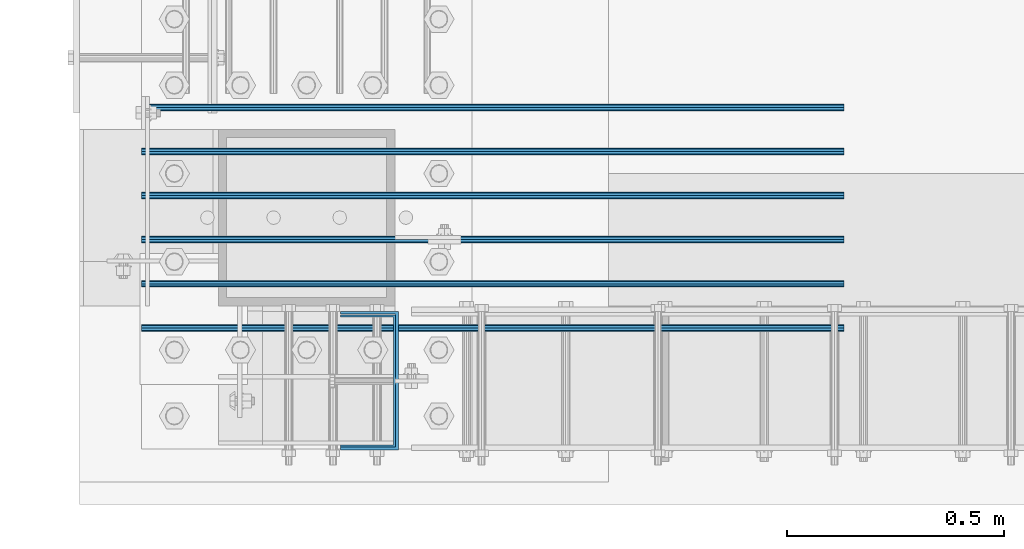
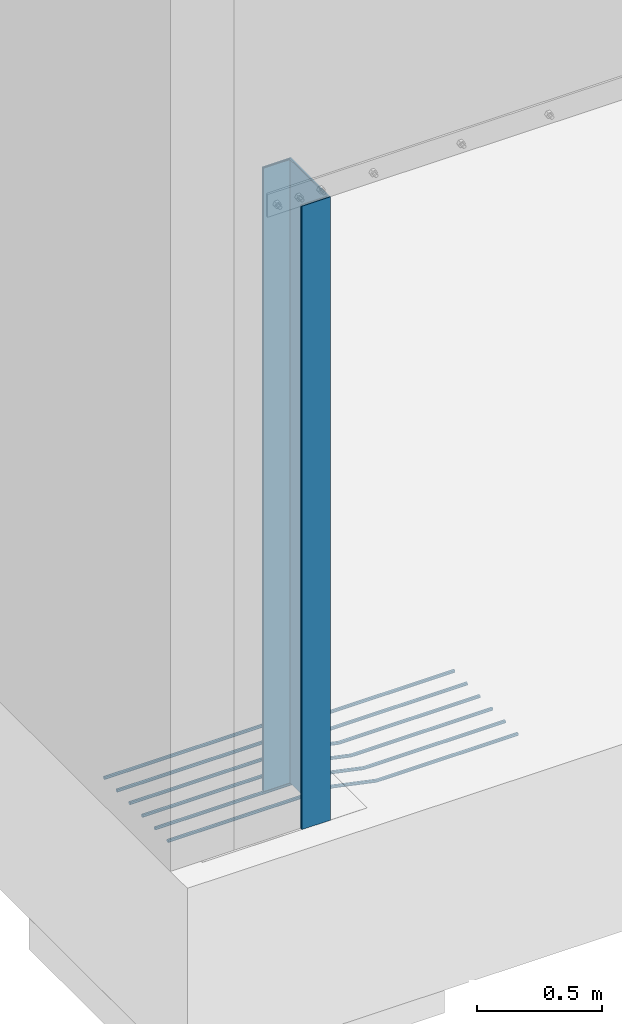
# One storey, part 906 of 1876: 8 beams, 3 elements without a shape of their own.
"""IFC2X3 building model written with IfcOpenShell, lengths in millimetres."""

from ifc_helpers import new_model, si_unit, frame, origin_with_axes, place, context, subcontext, project, spatial, faceted_brep, material, type_object, element, aggregate, save


model = new_model("IFC2X3")

# Units and contexts
model_context = context("Model", 3, precision=1e-05, world=origin_with_axes())
body_context = subcontext(model_context, "Body", "Model", "MODEL_VIEW")
ifc_project = project(units=[si_unit("LENGTHUNIT", "METRE", prefix="MILLI"), si_unit("AREAUNIT", "SQUARE_METRE"), si_unit("VOLUMEUNIT", "CUBIC_METRE"), si_unit("MASSUNIT", "GRAM", prefix="KILO"), si_unit("TIMEUNIT", "SECOND"), si_unit("PLANEANGLEUNIT", "RADIAN"), si_unit("SOLIDANGLEUNIT", "STERADIAN"), si_unit("THERMODYNAMICTEMPERATUREUNIT", "DEGREE_CELSIUS"), si_unit("LUMINOUSINTENSITYUNIT", "LUMEN")], contexts=[model_context])

# Site, building, storey
site_placement = place(None, origin_with_axes())
site = spatial("IfcSite", under=ifc_project, at=site_placement, CompositionType="ELEMENT")
building_placement = place(site_placement, origin_with_axes())
building = spatial("IfcBuilding", under=site, at=building_placement, Name="Undefined", CompositionType="ELEMENT")
storey_placement = place(building_placement, origin_with_axes())
storey = spatial("IfcBuildingStorey", under=building, at=storey_placement, Name="Undefined", CompositionType="ELEMENT", Elevation=0.0)

# Assembly, beams
assembly_1_placement = place(storey_placement, origin_with_axes())
assembly_1 = element("IfcElementAssembly", 1, at=assembly_1_placement, inside=storey, Name="PLATE", AssemblyPlace="NOTDEFINED", PredefinedType="RIGID_FRAME")
ifc_material_1 = material(Name="STEEL/A706-GR.60")
beam_type_1 = type_object("IfcBeamType", Name="5 REBAR", PredefinedType="NOTDEFINED")
beam_1_placement = place(assembly_1_placement, frame((-149.225003184072, -25349.2, -65.0875000000029), z_axis=(0.0, -1.0, 0.0), x_axis=(1.0, 0.0, 0.0)))
beam_1 = element("IfcBeam", 2, at=beam_1_placement, type_object=beam_type_1, material=ifc_material_1, Name="REBAR", ObjectType="5 REBAR", context=body_context, shape_type="Brep", body=[
    faceted_brep([(0.0, -7.9375, 0.0), (0.0, -5.61266007566822, -5.61266007566883), (760.671952535711, -5.61266007566822, -5.61266007566883), (760.671952535711, -7.9375, 0.0), (0.0, 0.0, -7.9375), (760.671952535711, 0.0, -7.9375), (0.0, 5.61266007566822, -5.61266007566883), (760.671952535711, 5.61266007566822, -5.61266007566883), (0.0, 7.9375, 0.0), (760.671952535711, 7.9375, 0.0), (0.0, 5.61266007566822, 5.61266007566883), (760.671952535711, 5.61266007566822, 5.61266007566883), (0.0, 0.0, 7.9375), (760.671952535711, 0.0, 7.9375), (0.0, -5.61266007566822, 5.61266007566883), (760.671952535711, -5.61266007566822, 5.61266007566883), (761.414482022857, -5.61266007566822, -5.61266007566883), (761.17195253571, -7.9375, 0.0), (762.0, 0.0, -7.9375), (762.585517977143, 5.61266007566822, -5.61266007566883), (762.82804746429, 7.9375, 0.0), (762.585517977143, 5.61266007566822, 5.61266007566883), (762.0, 0.0, 7.9375), (761.414482022857, -5.61266007566822, 5.61266007566883), (762.141023814993, -5.76591497301254, -5.61266007566883), (761.661186838667, -8.04069785274343, 0.0), (763.299452750969, -0.274103293312095, -7.9375), (764.457881686945, 5.21770838638835, -5.61266007566883), (764.937718663271, 7.49249126611924, 0.0), (764.457881686945, 5.21770838638835, 5.61266007566883), (763.299452750969, -0.274103293312095, 7.9375), (762.141023814993, -5.76591497301254, 5.61266007566883), (962.742130520086, -48.0802076234489, -5.61266007566883), (962.26229354376, -50.3549905031798, 0.0), (963.900559456062, -42.5883959437485, -7.9375), (965.058988392038, -37.096584264048, -5.61266007566883), (965.538825368364, -34.8218013843171, 0.0), (965.058988392038, -37.096584264048, 5.61266007566883), (963.900559456062, -42.5883959437485, 7.9375), (962.742130520086, -48.0802076234489, 5.61266007566883), (964.614494229888, -48.4751593127288, -5.61266007566883), (964.371964742742, -50.7999992370605, 0.0), (965.200012207031, -42.8624992370605, -7.9375), (965.785530184175, -37.2498391613923, -5.61266007566883), (966.028059671321, -34.9249992370605, 0.0), (965.785530184175, -37.2498391613923, 5.61266007566883), (965.200012207031, -42.8624992370605, 7.9375), (964.614494229888, -48.4751593127288, 5.61266007566883), (966.528059671321, -48.4751593127288, -5.61266007566883), (966.528059671321, -50.7999992370605, 0.0), (966.528059671321, -42.8624992370605, -7.9375), (966.528059671321, -37.2498391613923, -5.61266007566883), (966.528059671321, -34.9249992370605, 0.0), (966.528059671321, -37.2498391613923, 5.61266007566883), (966.528059671321, -42.8624992370605, 7.9375), (966.528059671321, -48.4751593127288, 5.61266007566883), (1619.25, -48.4751593127288, -5.61266007566883), (1619.25, -50.7999992370605, 0.0), (1619.25, -42.8624992370605, -7.9375), (1619.25, -37.2498391613923, -5.61266007566883), (1619.25, -34.9249992370605, 0.0), (1619.25, -37.2498391613923, 5.61266007566883), (1619.25, -42.8624992370605, 7.9375), (1619.25, -48.4751593127288, 5.61266007566883)], [[[0, 1, 2, 3]], [[1, 4, 5, 2]], [[4, 6, 7, 5]], [[6, 8, 9, 7]], [[8, 10, 11, 9]], [[10, 12, 13, 11]], [[12, 14, 15, 13]], [[14, 0, 3, 15]], [[14, 12, 10, 8, 6, 4, 1, 0]], [[3, 2, 16, 17]], [[2, 5, 18, 16]], [[5, 7, 19, 18]], [[7, 9, 20, 19]], [[9, 11, 21, 20]], [[11, 13, 22, 21]], [[13, 15, 23, 22]], [[15, 3, 17, 23]], [[17, 16, 24, 25]], [[16, 18, 26, 24]], [[18, 19, 27, 26]], [[19, 20, 28, 27]], [[20, 21, 29, 28]], [[21, 22, 30, 29]], [[22, 23, 31, 30]], [[23, 17, 25, 31]], [[25, 24, 32, 33]], [[24, 26, 34, 32]], [[26, 27, 35, 34]], [[27, 28, 36, 35]], [[28, 29, 37, 36]], [[29, 30, 38, 37]], [[30, 31, 39, 38]], [[31, 25, 33, 39]], [[33, 32, 40, 41]], [[32, 34, 42, 40]], [[34, 35, 43, 42]], [[35, 36, 44, 43]], [[36, 37, 45, 44]], [[37, 38, 46, 45]], [[38, 39, 47, 46]], [[39, 33, 41, 47]], [[41, 40, 48, 49]], [[40, 42, 50, 48]], [[42, 43, 51, 50]], [[43, 44, 52, 51]], [[44, 45, 53, 52]], [[45, 46, 54, 53]], [[46, 47, 55, 54]], [[47, 41, 49, 55]], [[49, 48, 56, 57]], [[48, 50, 58, 56]], [[50, 51, 59, 58]], [[51, 52, 60, 59]], [[52, 53, 61, 60]], [[53, 54, 62, 61]], [[54, 55, 63, 62]], [[55, 49, 57, 63]], [[58, 59, 60, 61, 62, 63, 57, 56]]]),
])
beam_2_placement = place(assembly_1_placement, frame((-149.225003184072, -25450.8, -65.0875000000029), z_axis=(0.0, -1.0, 0.0), x_axis=(1.0, 0.0, 0.0)))
beam_2 = element("IfcBeam", 3, at=beam_2_placement, type_object=beam_type_1, material=ifc_material_1, Name="REBAR", ObjectType="5 REBAR", context=body_context, shape_type="Brep", body=[
    faceted_brep([(0.0, -7.9375, 0.0), (0.0, -5.61266007566822, -5.61266007566883), (760.671952535711, -5.61266007566822, -5.61266007566883), (760.671952535711, -7.9375, 0.0), (0.0, 0.0, -7.9375), (760.671952535711, 0.0, -7.9375), (0.0, 5.61266007566822, -5.61266007566883), (760.671952535711, 5.61266007566822, -5.61266007566883), (0.0, 7.9375, 0.0), (760.671952535711, 7.9375, 0.0), (0.0, 5.61266007566822, 5.61266007566883), (760.671952535711, 5.61266007566822, 5.61266007566883), (0.0, 0.0, 7.9375), (760.671952535711, 0.0, 7.9375), (0.0, -5.61266007566822, 5.61266007566883), (760.671952535711, -5.61266007566822, 5.61266007566883), (761.414482022857, -5.61266007566822, -5.61266007566883), (761.17195253571, -7.9375, 0.0), (762.0, 0.0, -7.9375), (762.585517977143, 5.61266007566822, -5.61266007566883), (762.82804746429, 7.9375, 0.0), (762.585517977143, 5.61266007566822, 5.61266007566883), (762.0, 0.0, 7.9375), (761.414482022857, -5.61266007566822, 5.61266007566883), (762.141023814993, -5.76591497301254, -5.61266007566883), (761.661186838667, -8.04069785274343, 0.0), (763.299452750969, -0.274103293312095, -7.9375), (764.457881686945, 5.21770838638835, -5.61266007566883), (764.937718663271, 7.49249126611924, 0.0), (764.457881686945, 5.21770838638835, 5.61266007566883), (763.299452750969, -0.274103293312095, 7.9375), (762.141023814993, -5.76591497301254, 5.61266007566883), (962.742130520086, -48.0802076234489, -5.61266007566883), (962.26229354376, -50.3549905031798, 0.0), (963.900559456062, -42.5883959437485, -7.9375), (965.058988392038, -37.096584264048, -5.61266007566883), (965.538825368364, -34.8218013843171, 0.0), (965.058988392038, -37.096584264048, 5.61266007566883), (963.900559456062, -42.5883959437485, 7.9375), (962.742130520086, -48.0802076234489, 5.61266007566883), (964.614494229888, -48.4751593127288, -5.61266007566883), (964.371964742742, -50.7999992370605, 0.0), (965.200012207031, -42.8624992370605, -7.9375), (965.785530184175, -37.2498391613923, -5.61266007566883), (966.028059671321, -34.9249992370605, 0.0), (965.785530184175, -37.2498391613923, 5.61266007566883), (965.200012207031, -42.8624992370605, 7.9375), (964.614494229888, -48.4751593127288, 5.61266007566883), (966.528059671321, -48.4751593127288, -5.61266007566883), (966.528059671321, -50.7999992370605, 0.0), (966.528059671321, -42.8624992370605, -7.9375), (966.528059671321, -37.2498391613923, -5.61266007566883), (966.528059671321, -34.9249992370605, 0.0), (966.528059671321, -37.2498391613923, 5.61266007566883), (966.528059671321, -42.8624992370605, 7.9375), (966.528059671321, -48.4751593127288, 5.61266007566883), (1619.25, -48.4751593127288, -5.61266007566883), (1619.25, -50.7999992370605, 0.0), (1619.25, -42.8624992370605, -7.9375), (1619.25, -37.2498391613923, -5.61266007566883), (1619.25, -34.9249992370605, 0.0), (1619.25, -37.2498391613923, 5.61266007566883), (1619.25, -42.8624992370605, 7.9375), (1619.25, -48.4751593127288, 5.61266007566883)], [[[0, 1, 2, 3]], [[1, 4, 5, 2]], [[4, 6, 7, 5]], [[6, 8, 9, 7]], [[8, 10, 11, 9]], [[10, 12, 13, 11]], [[12, 14, 15, 13]], [[14, 0, 3, 15]], [[14, 12, 10, 8, 6, 4, 1, 0]], [[3, 2, 16, 17]], [[2, 5, 18, 16]], [[5, 7, 19, 18]], [[7, 9, 20, 19]], [[9, 11, 21, 20]], [[11, 13, 22, 21]], [[13, 15, 23, 22]], [[15, 3, 17, 23]], [[17, 16, 24, 25]], [[16, 18, 26, 24]], [[18, 19, 27, 26]], [[19, 20, 28, 27]], [[20, 21, 29, 28]], [[21, 22, 30, 29]], [[22, 23, 31, 30]], [[23, 17, 25, 31]], [[25, 24, 32, 33]], [[24, 26, 34, 32]], [[26, 27, 35, 34]], [[27, 28, 36, 35]], [[28, 29, 37, 36]], [[29, 30, 38, 37]], [[30, 31, 39, 38]], [[31, 25, 33, 39]], [[33, 32, 40, 41]], [[32, 34, 42, 40]], [[34, 35, 43, 42]], [[35, 36, 44, 43]], [[36, 37, 45, 44]], [[37, 38, 46, 45]], [[38, 39, 47, 46]], [[39, 33, 41, 47]], [[41, 40, 48, 49]], [[40, 42, 50, 48]], [[42, 43, 51, 50]], [[43, 44, 52, 51]], [[44, 45, 53, 52]], [[45, 46, 54, 53]], [[46, 47, 55, 54]], [[47, 41, 49, 55]], [[49, 48, 56, 57]], [[48, 50, 58, 56]], [[50, 51, 59, 58]], [[51, 52, 60, 59]], [[52, 53, 61, 60]], [[53, 54, 62, 61]], [[54, 55, 63, 62]], [[55, 49, 57, 63]], [[58, 59, 60, 61, 62, 63, 57, 56]]]),
])
beam_3_placement = place(assembly_1_placement, frame((-149.225003184072, -25247.6, -65.0875000000029), z_axis=(0.0, -1.0, 0.0), x_axis=(1.0, 0.0, 0.0)))
beam_3 = element("IfcBeam", 4, at=beam_3_placement, type_object=beam_type_1, material=ifc_material_1, Name="REBAR", ObjectType="5 REBAR", context=body_context, shape_type="Brep", body=[
    faceted_brep([(0.0, -7.9375, 0.0), (0.0, -5.61266007566822, -5.61266007566883), (760.671952535711, -5.61266007566822, -5.61266007566883), (760.671952535711, -7.9375, 0.0), (0.0, 0.0, -7.9375), (760.671952535711, 0.0, -7.9375), (0.0, 5.61266007566822, -5.61266007566883), (760.671952535711, 5.61266007566822, -5.61266007566883), (0.0, 7.9375, 0.0), (760.671952535711, 7.9375, 0.0), (0.0, 5.61266007566822, 5.61266007566883), (760.671952535711, 5.61266007566822, 5.61266007566883), (0.0, 0.0, 7.9375), (760.671952535711, 0.0, 7.9375), (0.0, -5.61266007566822, 5.61266007566883), (760.671952535711, -5.61266007566822, 5.61266007566883), (761.414482022857, -5.61266007566822, -5.61266007566883), (761.17195253571, -7.9375, 0.0), (762.0, 0.0, -7.9375), (762.585517977143, 5.61266007566822, -5.61266007566883), (762.82804746429, 7.9375, 0.0), (762.585517977143, 5.61266007566822, 5.61266007566883), (762.0, 0.0, 7.9375), (761.414482022857, -5.61266007566822, 5.61266007566883), (762.141023814993, -5.76591497301254, -5.61266007566883), (761.661186838667, -8.04069785274343, 0.0), (763.299452750969, -0.274103293312095, -7.9375), (764.457881686945, 5.21770838638835, -5.61266007566883), (764.937718663271, 7.49249126611924, 0.0), (764.457881686945, 5.21770838638835, 5.61266007566883), (763.299452750969, -0.274103293312095, 7.9375), (762.141023814993, -5.76591497301254, 5.61266007566883), (962.742130520086, -48.0802076234489, -5.61266007566883), (962.26229354376, -50.3549905031798, 0.0), (963.900559456062, -42.5883959437485, -7.9375), (965.058988392038, -37.096584264048, -5.61266007566883), (965.538825368364, -34.8218013843171, 0.0), (965.058988392038, -37.096584264048, 5.61266007566883), (963.900559456062, -42.5883959437485, 7.9375), (962.742130520086, -48.0802076234489, 5.61266007566883), (964.614494229888, -48.4751593127288, -5.61266007566883), (964.371964742742, -50.7999992370605, 0.0), (965.200012207031, -42.8624992370605, -7.9375), (965.785530184175, -37.2498391613923, -5.61266007566883), (966.028059671321, -34.9249992370605, 0.0), (965.785530184175, -37.2498391613923, 5.61266007566883), (965.200012207031, -42.8624992370605, 7.9375), (964.614494229888, -48.4751593127288, 5.61266007566883), (966.528059671321, -48.4751593127288, -5.61266007566883), (966.528059671321, -50.7999992370605, 0.0), (966.528059671321, -42.8624992370605, -7.9375), (966.528059671321, -37.2498391613923, -5.61266007566883), (966.528059671321, -34.9249992370605, 0.0), (966.528059671321, -37.2498391613923, 5.61266007566883), (966.528059671321, -42.8624992370605, 7.9375), (966.528059671321, -48.4751593127288, 5.61266007566883), (1619.25, -48.4751593127288, -5.61266007566883), (1619.25, -50.7999992370605, 0.0), (1619.25, -42.8624992370605, -7.9375), (1619.25, -37.2498391613923, -5.61266007566883), (1619.25, -34.9249992370605, 0.0), (1619.25, -37.2498391613923, 5.61266007566883), (1619.25, -42.8624992370605, 7.9375), (1619.25, -48.4751593127288, 5.61266007566883)], [[[0, 1, 2, 3]], [[1, 4, 5, 2]], [[4, 6, 7, 5]], [[6, 8, 9, 7]], [[8, 10, 11, 9]], [[10, 12, 13, 11]], [[12, 14, 15, 13]], [[14, 0, 3, 15]], [[14, 12, 10, 8, 6, 4, 1, 0]], [[3, 2, 16, 17]], [[2, 5, 18, 16]], [[5, 7, 19, 18]], [[7, 9, 20, 19]], [[9, 11, 21, 20]], [[11, 13, 22, 21]], [[13, 15, 23, 22]], [[15, 3, 17, 23]], [[17, 16, 24, 25]], [[16, 18, 26, 24]], [[18, 19, 27, 26]], [[19, 20, 28, 27]], [[20, 21, 29, 28]], [[21, 22, 30, 29]], [[22, 23, 31, 30]], [[23, 17, 25, 31]], [[25, 24, 32, 33]], [[24, 26, 34, 32]], [[26, 27, 35, 34]], [[27, 28, 36, 35]], [[28, 29, 37, 36]], [[29, 30, 38, 37]], [[30, 31, 39, 38]], [[31, 25, 33, 39]], [[33, 32, 40, 41]], [[32, 34, 42, 40]], [[34, 35, 43, 42]], [[35, 36, 44, 43]], [[36, 37, 45, 44]], [[37, 38, 46, 45]], [[38, 39, 47, 46]], [[39, 33, 41, 47]], [[41, 40, 48, 49]], [[40, 42, 50, 48]], [[42, 43, 51, 50]], [[43, 44, 52, 51]], [[44, 45, 53, 52]], [[45, 46, 54, 53]], [[46, 47, 55, 54]], [[47, 41, 49, 55]], [[49, 48, 56, 57]], [[48, 50, 58, 56]], [[50, 51, 59, 58]], [[51, 52, 60, 59]], [[52, 53, 61, 60]], [[53, 54, 62, 61]], [[54, 55, 63, 62]], [[55, 49, 57, 63]], [[58, 59, 60, 61, 62, 63, 57, 56]]]),
])
beam_4_placement = place(assembly_1_placement, frame((-149.225003184072, -25146.0, -65.0875000000029), z_axis=(0.0, -1.0, 0.0), x_axis=(1.0, 0.0, 0.0)))
beam_4 = element("IfcBeam", 5, at=beam_4_placement, type_object=beam_type_1, material=ifc_material_1, Name="REBAR", ObjectType="5 REBAR", context=body_context, shape_type="Brep", body=[
    faceted_brep([(0.0, -7.9375, 0.0), (0.0, -5.61266007566822, -5.61266007566883), (760.671952535711, -5.61266007566822, -5.61266007566883), (760.671952535711, -7.9375, 0.0), (0.0, 0.0, -7.9375), (760.671952535711, 0.0, -7.9375), (0.0, 5.61266007566822, -5.61266007566883), (760.671952535711, 5.61266007566822, -5.61266007566883), (0.0, 7.9375, 0.0), (760.671952535711, 7.9375, 0.0), (0.0, 5.61266007566822, 5.61266007566883), (760.671952535711, 5.61266007566822, 5.61266007566883), (0.0, 0.0, 7.9375), (760.671952535711, 0.0, 7.9375), (0.0, -5.61266007566822, 5.61266007566883), (760.671952535711, -5.61266007566822, 5.61266007566883), (761.414482022857, -5.61266007566822, -5.61266007566883), (761.17195253571, -7.9375, 0.0), (762.0, 0.0, -7.9375), (762.585517977143, 5.61266007566822, -5.61266007566883), (762.82804746429, 7.9375, 0.0), (762.585517977143, 5.61266007566822, 5.61266007566883), (762.0, 0.0, 7.9375), (761.414482022857, -5.61266007566822, 5.61266007566883), (762.141023814993, -5.76591497301254, -5.61266007566883), (761.661186838667, -8.04069785274343, 0.0), (763.299452750969, -0.274103293312095, -7.9375), (764.457881686945, 5.21770838638835, -5.61266007566883), (764.937718663271, 7.49249126611924, 0.0), (764.457881686945, 5.21770838638835, 5.61266007566883), (763.299452750969, -0.274103293312095, 7.9375), (762.141023814993, -5.76591497301254, 5.61266007566883), (962.742130520086, -48.0802076234489, -5.61266007566883), (962.26229354376, -50.3549905031798, 0.0), (963.900559456062, -42.5883959437485, -7.9375), (965.058988392038, -37.096584264048, -5.61266007566883), (965.538825368364, -34.8218013843171, 0.0), (965.058988392038, -37.096584264048, 5.61266007566883), (963.900559456062, -42.5883959437485, 7.9375), (962.742130520086, -48.0802076234489, 5.61266007566883), (964.614494229888, -48.4751593127288, -5.61266007566883), (964.371964742742, -50.7999992370605, 0.0), (965.200012207031, -42.8624992370605, -7.9375), (965.785530184175, -37.2498391613923, -5.61266007566883), (966.028059671321, -34.9249992370605, 0.0), (965.785530184175, -37.2498391613923, 5.61266007566883), (965.200012207031, -42.8624992370605, 7.9375), (964.614494229888, -48.4751593127288, 5.61266007566883), (966.528059671321, -48.4751593127288, -5.61266007566883), (966.528059671321, -50.7999992370605, 0.0), (966.528059671321, -42.8624992370605, -7.9375), (966.528059671321, -37.2498391613923, -5.61266007566883), (966.528059671321, -34.9249992370605, 0.0), (966.528059671321, -37.2498391613923, 5.61266007566883), (966.528059671321, -42.8624992370605, 7.9375), (966.528059671321, -48.4751593127288, 5.61266007566883), (1619.25, -48.4751593127288, -5.61266007566883), (1619.25, -50.7999992370605, 0.0), (1619.25, -42.8624992370605, -7.9375), (1619.25, -37.2498391613923, -5.61266007566883), (1619.25, -34.9249992370605, 0.0), (1619.25, -37.2498391613923, 5.61266007566883), (1619.25, -42.8624992370605, 7.9375), (1619.25, -48.4751593127288, 5.61266007566883)], [[[0, 1, 2, 3]], [[1, 4, 5, 2]], [[4, 6, 7, 5]], [[6, 8, 9, 7]], [[8, 10, 11, 9]], [[10, 12, 13, 11]], [[12, 14, 15, 13]], [[14, 0, 3, 15]], [[14, 12, 10, 8, 6, 4, 1, 0]], [[3, 2, 16, 17]], [[2, 5, 18, 16]], [[5, 7, 19, 18]], [[7, 9, 20, 19]], [[9, 11, 21, 20]], [[11, 13, 22, 21]], [[13, 15, 23, 22]], [[15, 3, 17, 23]], [[17, 16, 24, 25]], [[16, 18, 26, 24]], [[18, 19, 27, 26]], [[19, 20, 28, 27]], [[20, 21, 29, 28]], [[21, 22, 30, 29]], [[22, 23, 31, 30]], [[23, 17, 25, 31]], [[25, 24, 32, 33]], [[24, 26, 34, 32]], [[26, 27, 35, 34]], [[27, 28, 36, 35]], [[28, 29, 37, 36]], [[29, 30, 38, 37]], [[30, 31, 39, 38]], [[31, 25, 33, 39]], [[33, 32, 40, 41]], [[32, 34, 42, 40]], [[34, 35, 43, 42]], [[35, 36, 44, 43]], [[36, 37, 45, 44]], [[37, 38, 46, 45]], [[38, 39, 47, 46]], [[39, 33, 41, 47]], [[41, 40, 48, 49]], [[40, 42, 50, 48]], [[42, 43, 51, 50]], [[43, 44, 52, 51]], [[44, 45, 53, 52]], [[45, 46, 54, 53]], [[46, 47, 55, 54]], [[47, 41, 49, 55]], [[49, 48, 56, 57]], [[48, 50, 58, 56]], [[50, 51, 59, 58]], [[51, 52, 60, 59]], [[52, 53, 61, 60]], [[53, 54, 62, 61]], [[54, 55, 63, 62]], [[55, 49, 57, 63]], [[58, 59, 60, 61, 62, 63, 57, 56]]]),
])
beam_5_placement = place(assembly_1_placement, frame((-149.225003184072, -25552.4, -65.0875000000029), z_axis=(0.0, -1.0, 0.0), x_axis=(1.0, 0.0, 0.0)))
beam_5 = element("IfcBeam", 6, at=beam_5_placement, type_object=beam_type_1, material=ifc_material_1, Name="REBAR", ObjectType="5 REBAR", context=body_context, shape_type="Brep", body=[
    faceted_brep([(0.0, -7.9375, 0.0), (0.0, -5.61266007566822, -5.61266007566883), (760.671952535711, -5.61266007566822, -5.61266007566883), (760.671952535711, -7.9375, 0.0), (0.0, 0.0, -7.9375), (760.671952535711, 0.0, -7.9375), (0.0, 5.61266007566822, -5.61266007566883), (760.671952535711, 5.61266007566822, -5.61266007566883), (0.0, 7.9375, 0.0), (760.671952535711, 7.9375, 0.0), (0.0, 5.61266007566822, 5.61266007566883), (760.671952535711, 5.61266007566822, 5.61266007566883), (0.0, 0.0, 7.9375), (760.671952535711, 0.0, 7.9375), (0.0, -5.61266007566822, 5.61266007566883), (760.671952535711, -5.61266007566822, 5.61266007566883), (761.414482022857, -5.61266007566822, -5.61266007566883), (761.17195253571, -7.9375, 0.0), (762.0, 0.0, -7.9375), (762.585517977143, 5.61266007566822, -5.61266007566883), (762.82804746429, 7.9375, 0.0), (762.585517977143, 5.61266007566822, 5.61266007566883), (762.0, 0.0, 7.9375), (761.414482022857, -5.61266007566822, 5.61266007566883), (762.141023814993, -5.76591497301254, -5.61266007566883), (761.661186838667, -8.04069785274343, 0.0), (763.299452750969, -0.274103293312095, -7.9375), (764.457881686945, 5.21770838638835, -5.61266007566883), (764.937718663271, 7.49249126611924, 0.0), (764.457881686945, 5.21770838638835, 5.61266007566883), (763.299452750969, -0.274103293312095, 7.9375), (762.141023814993, -5.76591497301254, 5.61266007566883), (962.742130520086, -48.0802076234489, -5.61266007566883), (962.26229354376, -50.3549905031798, 0.0), (963.900559456062, -42.5883959437485, -7.9375), (965.058988392038, -37.096584264048, -5.61266007566883), (965.538825368364, -34.8218013843171, 0.0), (965.058988392038, -37.096584264048, 5.61266007566883), (963.900559456062, -42.5883959437485, 7.9375), (962.742130520086, -48.0802076234489, 5.61266007566883), (964.614494229888, -48.4751593127288, -5.61266007566883), (964.371964742742, -50.7999992370605, 0.0), (965.200012207031, -42.8624992370605, -7.9375), (965.785530184175, -37.2498391613923, -5.61266007566883), (966.028059671321, -34.9249992370605, 0.0), (965.785530184175, -37.2498391613923, 5.61266007566883), (965.200012207031, -42.8624992370605, 7.9375), (964.614494229888, -48.4751593127288, 5.61266007566883), (966.528059671321, -48.4751593127288, -5.61266007566883), (966.528059671321, -50.7999992370605, 0.0), (966.528059671321, -42.8624992370605, -7.9375), (966.528059671321, -37.2498391613923, -5.61266007566883), (966.528059671321, -34.9249992370605, 0.0), (966.528059671321, -37.2498391613923, 5.61266007566883), (966.528059671321, -42.8624992370605, 7.9375), (966.528059671321, -48.4751593127288, 5.61266007566883), (1619.25, -48.4751593127288, -5.61266007566883), (1619.25, -50.7999992370605, 0.0), (1619.25, -42.8624992370605, -7.9375), (1619.25, -37.2498391613923, -5.61266007566883), (1619.25, -34.9249992370605, 0.0), (1619.25, -37.2498391613923, 5.61266007566883), (1619.25, -42.8624992370605, 7.9375), (1619.25, -48.4751593127288, 5.61266007566883)], [[[0, 1, 2, 3]], [[1, 4, 5, 2]], [[4, 6, 7, 5]], [[6, 8, 9, 7]], [[8, 10, 11, 9]], [[10, 12, 13, 11]], [[12, 14, 15, 13]], [[14, 0, 3, 15]], [[14, 12, 10, 8, 6, 4, 1, 0]], [[3, 2, 16, 17]], [[2, 5, 18, 16]], [[5, 7, 19, 18]], [[7, 9, 20, 19]], [[9, 11, 21, 20]], [[11, 13, 22, 21]], [[13, 15, 23, 22]], [[15, 3, 17, 23]], [[17, 16, 24, 25]], [[16, 18, 26, 24]], [[18, 19, 27, 26]], [[19, 20, 28, 27]], [[20, 21, 29, 28]], [[21, 22, 30, 29]], [[22, 23, 31, 30]], [[23, 17, 25, 31]], [[25, 24, 32, 33]], [[24, 26, 34, 32]], [[26, 27, 35, 34]], [[27, 28, 36, 35]], [[28, 29, 37, 36]], [[29, 30, 38, 37]], [[30, 31, 39, 38]], [[31, 25, 33, 39]], [[33, 32, 40, 41]], [[32, 34, 42, 40]], [[34, 35, 43, 42]], [[35, 36, 44, 43]], [[36, 37, 45, 44]], [[37, 38, 46, 45]], [[38, 39, 47, 46]], [[39, 33, 41, 47]], [[41, 40, 48, 49]], [[40, 42, 50, 48]], [[42, 43, 51, 50]], [[43, 44, 52, 51]], [[44, 45, 53, 52]], [[45, 46, 54, 53]], [[46, 47, 55, 54]], [[47, 41, 49, 55]], [[49, 48, 56, 57]], [[48, 50, 58, 56]], [[50, 51, 59, 58]], [[51, 52, 60, 59]], [[52, 53, 61, 60]], [[53, 54, 62, 61]], [[54, 55, 63, 62]], [[55, 49, 57, 63]], [[58, 59, 60, 61, 62, 63, 57, 56]]]),
])
beam_6_placement = place(assembly_1_placement, frame((-149.225003184072, -25654.0, -65.0875000000029), z_axis=(0.0, -1.0, 0.0), x_axis=(1.0, 0.0, 0.0)))
beam_6 = element("IfcBeam", 7, at=beam_6_placement, type_object=beam_type_1, material=ifc_material_1, Name="REBAR", ObjectType="5 REBAR", context=body_context, shape_type="Brep", body=[
    faceted_brep([(0.0, -7.9375, 0.0), (0.0, -5.61266007566822, -5.61266007566883), (760.671952535711, -5.61266007566822, -5.61266007566883), (760.671952535711, -7.9375, 0.0), (0.0, 0.0, -7.9375), (760.671952535711, 0.0, -7.9375), (0.0, 5.61266007566822, -5.61266007566883), (760.671952535711, 5.61266007566822, -5.61266007566883), (0.0, 7.9375, 0.0), (760.671952535711, 7.9375, 0.0), (0.0, 5.61266007566822, 5.61266007566883), (760.671952535711, 5.61266007566822, 5.61266007566883), (0.0, 0.0, 7.9375), (760.671952535711, 0.0, 7.9375), (0.0, -5.61266007566822, 5.61266007566883), (760.671952535711, -5.61266007566822, 5.61266007566883), (761.414482022857, -5.61266007566822, -5.61266007566883), (761.17195253571, -7.9375, 0.0), (762.0, 0.0, -7.9375), (762.585517977143, 5.61266007566822, -5.61266007566883), (762.82804746429, 7.9375, 0.0), (762.585517977143, 5.61266007566822, 5.61266007566883), (762.0, 0.0, 7.9375), (761.414482022857, -5.61266007566822, 5.61266007566883), (762.141023814993, -5.76591497301254, -5.61266007566883), (761.661186838667, -8.04069785274343, 0.0), (763.299452750969, -0.274103293312095, -7.9375), (764.457881686945, 5.21770838638835, -5.61266007566883), (764.937718663271, 7.49249126611924, 0.0), (764.457881686945, 5.21770838638835, 5.61266007566883), (763.299452750969, -0.274103293312095, 7.9375), (762.141023814993, -5.76591497301254, 5.61266007566883), (962.742130520086, -48.0802076234489, -5.61266007566883), (962.26229354376, -50.3549905031798, 0.0), (963.900559456062, -42.5883959437485, -7.9375), (965.058988392038, -37.096584264048, -5.61266007566883), (965.538825368364, -34.8218013843171, 0.0), (965.058988392038, -37.096584264048, 5.61266007566883), (963.900559456062, -42.5883959437485, 7.9375), (962.742130520086, -48.0802076234489, 5.61266007566883), (964.614494229888, -48.4751593127288, -5.61266007566883), (964.371964742742, -50.7999992370605, 0.0), (965.200012207031, -42.8624992370605, -7.9375), (965.785530184175, -37.2498391613923, -5.61266007566883), (966.028059671321, -34.9249992370605, 0.0), (965.785530184175, -37.2498391613923, 5.61266007566883), (965.200012207031, -42.8624992370605, 7.9375), (964.614494229888, -48.4751593127288, 5.61266007566883), (966.528059671321, -48.4751593127288, -5.61266007566883), (966.528059671321, -50.7999992370605, 0.0), (966.528059671321, -42.8624992370605, -7.9375), (966.528059671321, -37.2498391613923, -5.61266007566883), (966.528059671321, -34.9249992370605, 0.0), (966.528059671321, -37.2498391613923, 5.61266007566883), (966.528059671321, -42.8624992370605, 7.9375), (966.528059671321, -48.4751593127288, 5.61266007566883), (1619.25, -48.4751593127288, -5.61266007566883), (1619.25, -50.7999992370605, 0.0), (1619.25, -42.8624992370605, -7.9375), (1619.25, -37.2498391613923, -5.61266007566883), (1619.25, -34.9249992370605, 0.0), (1619.25, -37.2498391613923, 5.61266007566883), (1619.25, -42.8624992370605, 7.9375), (1619.25, -48.4751593127288, 5.61266007566883)], [[[0, 1, 2, 3]], [[1, 4, 5, 2]], [[4, 6, 7, 5]], [[6, 8, 9, 7]], [[8, 10, 11, 9]], [[10, 12, 13, 11]], [[12, 14, 15, 13]], [[14, 0, 3, 15]], [[14, 12, 10, 8, 6, 4, 1, 0]], [[3, 2, 16, 17]], [[2, 5, 18, 16]], [[5, 7, 19, 18]], [[7, 9, 20, 19]], [[9, 11, 21, 20]], [[11, 13, 22, 21]], [[13, 15, 23, 22]], [[15, 3, 17, 23]], [[17, 16, 24, 25]], [[16, 18, 26, 24]], [[18, 19, 27, 26]], [[19, 20, 28, 27]], [[20, 21, 29, 28]], [[21, 22, 30, 29]], [[22, 23, 31, 30]], [[23, 17, 25, 31]], [[25, 24, 32, 33]], [[24, 26, 34, 32]], [[26, 27, 35, 34]], [[27, 28, 36, 35]], [[28, 29, 37, 36]], [[29, 30, 38, 37]], [[30, 31, 39, 38]], [[31, 25, 33, 39]], [[33, 32, 40, 41]], [[32, 34, 42, 40]], [[34, 35, 43, 42]], [[35, 36, 44, 43]], [[36, 37, 45, 44]], [[37, 38, 46, 45]], [[38, 39, 47, 46]], [[39, 33, 41, 47]], [[41, 40, 48, 49]], [[40, 42, 50, 48]], [[42, 43, 51, 50]], [[43, 44, 52, 51]], [[44, 45, 53, 52]], [[45, 46, 54, 53]], [[46, 47, 55, 54]], [[47, 41, 49, 55]], [[49, 48, 56, 57]], [[48, 50, 58, 56]], [[50, 51, 59, 58]], [[51, 52, 60, 59]], [[52, 53, 61, 60]], [[53, 54, 62, 61]], [[54, 55, 63, 62]], [[55, 49, 57, 63]], [[58, 59, 60, 61, 62, 63, 57, 56]]]),
])
aggregate(assembly_1, [beam_1, beam_2, beam_3, beam_4, beam_5, beam_6])

# Assembly, beam
assembly_2_placement = place(storey_placement, origin_with_axes())
assembly_2 = element("IfcElementAssembly", 8, at=assembly_2_placement, inside=storey, Name="BEAM", AssemblyPlace="NOTDEFINED", PredefinedType="REINFORCEMENT_UNIT")
ifc_material_2 = material(Name="CONCRETE/5000")
beam_type_2 = type_object("IfcBeamType", PredefinedType="NOTDEFINED")
beam_7_placement = place(assembly_2_placement, frame((309.562001606972, -25926.256, 1524.0), z_axis=(0.0, 0.0, 1.0), x_axis=(1.0, 0.0, 0.0)))
beam_7 = element("IfcBeam", 9, at=beam_7_placement, type_object=beam_type_2, material=ifc_material_2, Name="BEAM", context=body_context, shape_type="Brep", body=[
    faceted_brep([(1.60071067512035e-10, -2.38100000000122, -1524.0), (1.60071067512035e-10, -2.38100000000122, 1524.0), (-1.60071067512035e-10, 2.38099999999758, 1524.0), (-1.60071067512035e-10, 2.38099999999758, -1524.0), (122.237998962702, 2.38099999183942, 1524.0), (122.237998962702, 2.38099999183942, -1524.0), (126.999998724603, -2.38100000847589, -1524.0), (126.999998724603, -2.38100000847589, 1524.0), (122.238013726454, 297.655987784639, 1524.0), (122.238013726454, 297.655987784639, -1524.0), (127.000013964554, 302.417987546543, -1524.0), (127.000013964554, 302.417987546543, 1524.0), (1.47643368109129e-05, 297.655993896484, 1524.0), (1.47643368109129e-05, 297.655993896484, -1524.0), (1.50024361573742e-05, 302.417993896484, 1524.0), (1.50024361573742e-05, 302.417993896484, -1524.0)], [[[0, 1, 2, 3]], [[3, 2, 4, 5]], [[1, 0, 6, 7]], [[5, 4, 8, 9]], [[7, 6, 10, 11]], [[9, 8, 12, 13]], [[8, 4, 2, 1, 7, 11, 14, 12]], [[11, 10, 15, 14]], [[10, 6, 0, 3, 5, 9, 13, 15]], [[14, 15, 13, 12]]]),
])
aggregate(assembly_2, [beam_7])

assembly_3_placement = place(storey_placement, origin_with_axes())
assembly_3 = element("IfcElementAssembly", 10, at=assembly_3_placement, inside=storey, Name="BENT PLATE", AssemblyPlace="NOTDEFINED", PredefinedType="RIGID_FRAME")
ifc_material_3 = material(Name="STEEL/A36")
beam_type_3 = type_object("IfcBeamType", PredefinedType="NOTDEFINED")
beam_8_placement = place(assembly_3_placement, frame((309.562001725862, -25931.812, 1524.0), z_axis=(0.0, 0.0, 1.0), x_axis=(1.0, 0.0, 0.0)))
beam_8 = element("IfcBeam", 11, at=beam_8_placement, type_object=beam_type_3, material=ifc_material_3, Name="BENT PLATE", context=body_context, shape_type="Brep", body=[
    faceted_brep([(9.877112461254e-10, -3.17499999999563, -1524.0), (9.877112461254e-10, -3.17499999999563, 1524.0), (-9.88620740827173e-10, 3.17500000000291, 1524.0), (-9.88620740827173e-10, 3.17500000000291, -1524.0), (126.999999999999, 3.17499999999927, 1524.0), (126.999999999999, 3.17499999999927, -1524.0), (133.349999999999, -3.17499999999927, -1524.0), (133.349999999999, -3.17499999999927, 1524.0), (126.999999999999, 309.561474609374, 1524.0), (126.999999999999, 309.561474609374, -1524.0), (133.349999999999, 315.911474609373, -1524.0), (133.349999999999, 315.911474609373, 1524.0), (-2.37773747358005e-07, 309.561474609374, 1524.0), (-2.37773747358005e-07, 309.561474609374, -1524.0), (-2.37773747358005e-07, 315.911474609373, 1524.0), (-2.37773747358005e-07, 315.911474609373, -1524.0)], [[[0, 1, 2, 3]], [[3, 2, 4, 5]], [[1, 0, 6, 7]], [[5, 4, 8, 9]], [[7, 6, 10, 11]], [[9, 8, 12, 13]], [[8, 4, 2, 1, 7, 11, 14, 12]], [[11, 10, 15, 14]], [[10, 6, 0, 3, 5, 9, 13, 15]], [[14, 15, 13, 12]]]),
])
aggregate(assembly_3, [beam_8])

save(model, "model.ifc")
